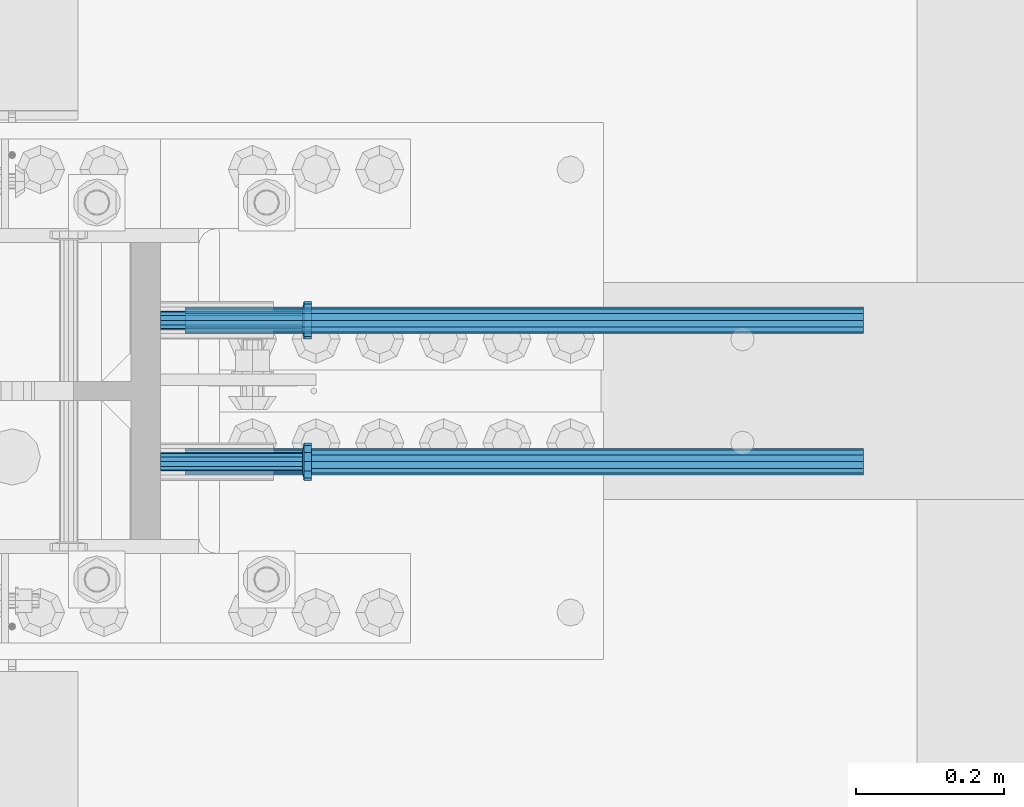
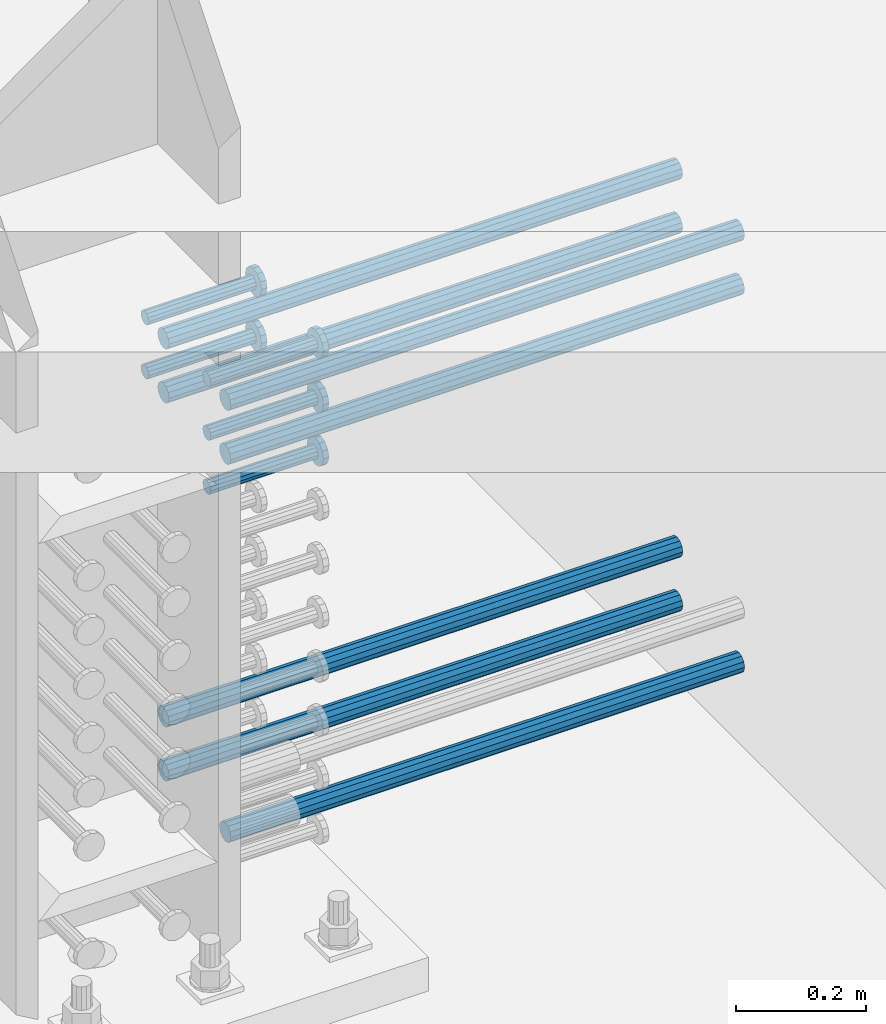
# One storey, part 1195 of 1763: 12 beams, 8 elements without a shape of their own.
"""IFC2X3 building model written with IfcOpenShell, lengths in millimetres."""

from ifc_helpers import new_model, si_unit, frame, origin_with_axes, place, context, subcontext, project, spatial, faceted_brep, material, type_object, element, aggregate, save


model = new_model("IFC2X3")

# Units and contexts
model_context = context("Model", 3, precision=1e-05, world=origin_with_axes())
body_context = subcontext(model_context, "Body", "Model", "MODEL_VIEW")
ifc_project = project(units=[si_unit("LENGTHUNIT", "METRE", prefix="MILLI"), si_unit("AREAUNIT", "SQUARE_METRE"), si_unit("VOLUMEUNIT", "CUBIC_METRE"), si_unit("MASSUNIT", "GRAM", prefix="KILO"), si_unit("TIMEUNIT", "SECOND"), si_unit("PLANEANGLEUNIT", "RADIAN"), si_unit("SOLIDANGLEUNIT", "STERADIAN"), si_unit("THERMODYNAMICTEMPERATUREUNIT", "DEGREE_CELSIUS"), si_unit("LUMINOUSINTENSITYUNIT", "LUMEN")], contexts=[model_context])

# Site, building, storey
site_placement = place(None, origin_with_axes())
site = spatial("IfcSite", under=ifc_project, at=site_placement, CompositionType="ELEMENT")
building_placement = place(site_placement, origin_with_axes())
building = spatial("IfcBuilding", under=site, at=building_placement, Name="Undefined", CompositionType="ELEMENT")
storey_placement = place(building_placement, origin_with_axes())
storey = spatial("IfcBuildingStorey", under=building, at=storey_placement, Name="Undefined", CompositionType="ELEMENT", Elevation=0.0)

# Assembly, beam
assembly_1_placement = place(storey_placement, origin_with_axes())
assembly_1 = element("IfcElementAssembly", 1, at=assembly_1_placement, inside=storey, Name="REBAR", AssemblyPlace="NOTDEFINED", PredefinedType="RIGID_FRAME")
ifc_material_1 = material(Name="STEEL/A706-GR.80")
beam_type_1 = type_object("IfcBeamType", Name="#11 REBAR", PredefinedType="NOTDEFINED")
beam_1_placement = place(assembly_1_placement, frame((-72258.2462049617, 552.449999999157, 4165.60000000003), z_axis=(0.0, 0.0, 1.0), x_axis=(1.0, 0.0, 0.0)))
beam_1 = element("IfcBeam", 2, at=beam_1_placement, type_object=beam_type_1, material=ifc_material_1, Name="REBAR", ObjectType="#11 REBAR", context=body_context, shape_type="Brep", body=[
    faceted_brep([(0.0, -17.9069999999992, 0.0), (0.0, -15.507916905568, -8.95349999999962), (914.400000001086, -15.507916905568, -8.95349999999962), (914.400000001086, -17.9069999999992, 0.0), (0.0, -8.95349999999962, -15.507916905568), (914.400000001086, -8.95349999999962, -15.507916905568), (0.0, 0.0, -17.9070000000002), (914.400000001086, 0.0, -17.9070000000002), (0.0, 8.95349999999962, -15.507916905568), (914.400000001086, 8.95349999999962, -15.507916905568), (0.0, 15.507916905568, -8.95349999999962), (914.400000001086, 15.507916905568, -8.95349999999962), (0.0, 17.9069999999992, 0.0), (914.400000001086, 17.9069999999992, 0.0), (0.0, 15.507916905568, 8.95349999999962), (914.400000001086, 15.507916905568, 8.95349999999962), (0.0, 8.95349999999962, 15.507916905568), (914.400000001086, 8.95349999999962, 15.507916905568), (0.0, 0.0, 17.9070000000002), (914.400000001086, 0.0, 17.9070000000002), (0.0, -8.95349999999962, 15.507916905568), (914.400000001086, -8.95349999999962, 15.507916905568), (0.0, -15.507916905568, 8.95349999999962), (914.400000001086, -15.507916905568, 8.95349999999962)], [[[0, 1, 2, 3]], [[1, 4, 5, 2]], [[4, 6, 7, 5]], [[6, 8, 9, 7]], [[8, 10, 11, 9]], [[10, 12, 13, 11]], [[12, 14, 15, 13]], [[14, 16, 17, 15]], [[16, 18, 19, 17]], [[18, 20, 21, 19]], [[20, 22, 23, 21]], [[22, 0, 3, 23]], [[5, 7, 9, 11, 13, 15, 17, 19, 21, 23, 3, 2]], [[22, 20, 18, 16, 14, 12, 10, 8, 6, 4, 1, 0]]]),
])
aggregate(assembly_1, [beam_1])

assembly_2_placement = place(storey_placement, origin_with_axes())
assembly_2 = element("IfcElementAssembly", 3, at=assembly_2_placement, inside=storey, Name="REBAR", AssemblyPlace="NOTDEFINED", PredefinedType="RIGID_FRAME")
beam_2_placement = place(assembly_2_placement, frame((-72258.2462736235, 361.949999999746, 4064.00000000003), z_axis=(0.0, 0.0, 1.0), x_axis=(1.0, 0.0, 0.0)))
beam_2 = element("IfcBeam", 4, at=beam_2_placement, type_object=beam_type_1, material=ifc_material_1, Name="REBAR", ObjectType="#11 REBAR", context=body_context, shape_type="Brep", body=[
    faceted_brep([(0.0, -17.9069999999992, 0.0), (0.0, -15.507916905568, -8.95349999999962), (914.400000001086, -15.507916905568, -8.95349999999962), (914.400000001086, -17.9069999999992, 0.0), (0.0, -8.95349999999962, -15.507916905568), (914.400000001086, -8.95349999999962, -15.507916905568), (0.0, 0.0, -17.9070000000002), (914.400000001086, 0.0, -17.9070000000002), (0.0, 8.95349999999962, -15.507916905568), (914.400000001086, 8.95349999999962, -15.507916905568), (0.0, 15.507916905568, -8.95349999999962), (914.400000001086, 15.507916905568, -8.95349999999962), (0.0, 17.9069999999992, 0.0), (914.400000001086, 17.9069999999992, 0.0), (0.0, 15.507916905568, 8.95349999999962), (914.400000001086, 15.507916905568, 8.95349999999962), (0.0, 8.95349999999962, 15.507916905568), (914.400000001086, 8.95349999999962, 15.507916905568), (0.0, 0.0, 17.9070000000002), (914.400000001086, 0.0, 17.9070000000002), (0.0, -8.95349999999962, 15.507916905568), (914.400000001086, -8.95349999999962, 15.507916905568), (0.0, -15.507916905568, 8.95349999999962), (914.400000001086, -15.507916905568, 8.95349999999962)], [[[0, 1, 2, 3]], [[1, 4, 5, 2]], [[4, 6, 7, 5]], [[6, 8, 9, 7]], [[8, 10, 11, 9]], [[10, 12, 13, 11]], [[12, 14, 15, 13]], [[14, 16, 17, 15]], [[16, 18, 19, 17]], [[18, 20, 21, 19]], [[20, 22, 23, 21]], [[22, 0, 3, 23]], [[5, 7, 9, 11, 13, 15, 17, 19, 21, 23, 3, 2]], [[22, 20, 18, 16, 14, 12, 10, 8, 6, 4, 1, 0]]]),
])
aggregate(assembly_2, [beam_2])

assembly_3_placement = place(storey_placement, origin_with_axes())
assembly_3 = element("IfcElementAssembly", 5, at=assembly_3_placement, inside=storey, Name="REBAR", AssemblyPlace="NOTDEFINED", PredefinedType="RIGID_FRAME")
beam_3_placement = place(assembly_3_placement, frame((-72258.2462049617, 552.44999999916, 4064.00000000003), z_axis=(0.0, 0.0, 1.0), x_axis=(1.0, 0.0, 0.0)))
beam_3 = element("IfcBeam", 6, at=beam_3_placement, type_object=beam_type_1, material=ifc_material_1, Name="REBAR", ObjectType="#11 REBAR", context=body_context, shape_type="Brep", body=[
    faceted_brep([(0.0, -17.9069999999992, 0.0), (0.0, -15.507916905568, -8.95349999999962), (914.400000001086, -15.507916905568, -8.95349999999962), (914.400000001086, -17.9069999999992, 0.0), (0.0, -8.95349999999962, -15.507916905568), (914.400000001086, -8.95349999999962, -15.507916905568), (0.0, 0.0, -17.9070000000002), (914.400000001086, 0.0, -17.9070000000002), (0.0, 8.95349999999962, -15.507916905568), (914.400000001086, 8.95349999999962, -15.507916905568), (0.0, 15.507916905568, -8.95349999999962), (914.400000001086, 15.507916905568, -8.95349999999962), (0.0, 17.9069999999992, 0.0), (914.400000001086, 17.9069999999992, 0.0), (0.0, 15.507916905568, 8.95349999999962), (914.400000001086, 15.507916905568, 8.95349999999962), (0.0, 8.95349999999962, 15.507916905568), (914.400000001086, 8.95349999999962, 15.507916905568), (0.0, 0.0, 17.9070000000002), (914.400000001086, 0.0, 17.9070000000002), (0.0, -8.95349999999962, 15.507916905568), (914.400000001086, -8.95349999999962, 15.507916905568), (0.0, -15.507916905568, 8.95349999999962), (914.400000001086, -15.507916905568, 8.95349999999962)], [[[0, 1, 2, 3]], [[1, 4, 5, 2]], [[4, 6, 7, 5]], [[6, 8, 9, 7]], [[8, 10, 11, 9]], [[10, 12, 13, 11]], [[12, 14, 15, 13]], [[14, 16, 17, 15]], [[16, 18, 19, 17]], [[18, 20, 21, 19]], [[20, 22, 23, 21]], [[22, 0, 3, 23]], [[5, 7, 9, 11, 13, 15, 17, 19, 21, 23, 3, 2]], [[22, 20, 18, 16, 14, 12, 10, 8, 6, 4, 1, 0]]]),
])
aggregate(assembly_3, [beam_3])

assembly_4_placement = place(storey_placement, origin_with_axes())
assembly_4 = element("IfcElementAssembly", 7, at=assembly_4_placement, inside=storey, Name="REBAR", AssemblyPlace="NOTDEFINED", PredefinedType="RIGID_FRAME")
beam_4_placement = place(assembly_4_placement, frame((-72258.246342359, 361.949999999741, 4876.80000000009), z_axis=(0.0, 0.0, 1.0), x_axis=(1.0, 0.0, 0.0)))
beam_4 = element("IfcBeam", 8, at=beam_4_placement, type_object=beam_type_1, material=ifc_material_1, Name="REBAR", ObjectType="#11 REBAR", context=body_context, shape_type="Brep", body=[
    faceted_brep([(0.0, -17.9069999999992, 0.0), (0.0, -15.507916905568, -8.95349999999962), (914.400000001086, -15.507916905568, -8.95349999999962), (914.400000001086, -17.9069999999992, 0.0), (0.0, -8.95349999999962, -15.507916905568), (914.400000001086, -8.95349999999962, -15.507916905568), (0.0, 0.0, -17.9070000000002), (914.400000001086, 0.0, -17.9070000000002), (0.0, 8.95349999999962, -15.507916905568), (914.400000001086, 8.95349999999962, -15.507916905568), (0.0, 15.507916905568, -8.95349999999962), (914.400000001086, 15.507916905568, -8.95349999999962), (0.0, 17.9069999999992, 0.0), (914.400000001086, 17.9069999999992, 0.0), (0.0, 15.507916905568, 8.95349999999962), (914.400000001086, 15.507916905568, 8.95349999999962), (0.0, 8.95349999999962, 15.507916905568), (914.400000001086, 8.95349999999962, 15.507916905568), (0.0, 0.0, 17.9070000000002), (914.400000001086, 0.0, 17.9070000000002), (0.0, -8.95349999999962, 15.507916905568), (914.400000001086, -8.95349999999962, 15.507916905568), (0.0, -15.507916905568, 8.95349999999962), (914.400000001086, -15.507916905568, 8.95349999999962)], [[[0, 1, 2, 3]], [[1, 4, 5, 2]], [[4, 6, 7, 5]], [[6, 8, 9, 7]], [[8, 10, 11, 9]], [[10, 12, 13, 11]], [[12, 14, 15, 13]], [[14, 16, 17, 15]], [[16, 18, 19, 17]], [[18, 20, 21, 19]], [[20, 22, 23, 21]], [[22, 0, 3, 23]], [[5, 7, 9, 11, 13, 15, 17, 19, 21, 23, 3, 2]], [[22, 20, 18, 16, 14, 12, 10, 8, 6, 4, 1, 0]]]),
])
aggregate(assembly_4, [beam_4])

assembly_5_placement = place(storey_placement, origin_with_axes())
assembly_5 = element("IfcElementAssembly", 9, at=assembly_5_placement, inside=storey, Name="REBAR", AssemblyPlace="NOTDEFINED", PredefinedType="RIGID_FRAME")
beam_5_placement = place(assembly_5_placement, frame((-72258.2462736978, 552.449999999155, 4876.80000000009), z_axis=(0.0, 0.0, 1.0), x_axis=(1.0, 0.0, 0.0)))
beam_5 = element("IfcBeam", 10, at=beam_5_placement, type_object=beam_type_1, material=ifc_material_1, Name="REBAR", ObjectType="#11 REBAR", context=body_context, shape_type="Brep", body=[
    faceted_brep([(0.0, -17.9069999999992, 0.0), (0.0, -15.507916905568, -8.95349999999962), (914.400000001086, -15.507916905568, -8.95349999999962), (914.400000001086, -17.9069999999992, 0.0), (0.0, -8.95349999999962, -15.507916905568), (914.400000001086, -8.95349999999962, -15.507916905568), (0.0, 0.0, -17.9070000000002), (914.400000001086, 0.0, -17.9070000000002), (0.0, 8.95349999999962, -15.507916905568), (914.400000001086, 8.95349999999962, -15.507916905568), (0.0, 15.507916905568, -8.95349999999962), (914.400000001086, 15.507916905568, -8.95349999999962), (0.0, 17.9069999999992, 0.0), (914.400000001086, 17.9069999999992, 0.0), (0.0, 15.507916905568, 8.95349999999962), (914.400000001086, 15.507916905568, 8.95349999999962), (0.0, 8.95349999999962, 15.507916905568), (914.400000001086, 8.95349999999962, 15.507916905568), (0.0, 0.0, 17.9070000000002), (914.400000001086, 0.0, 17.9070000000002), (0.0, -8.95349999999962, 15.507916905568), (914.400000001086, -8.95349999999962, 15.507916905568), (0.0, -15.507916905568, 8.95349999999962), (914.400000001086, -15.507916905568, 8.95349999999962)], [[[0, 1, 2, 3]], [[1, 4, 5, 2]], [[4, 6, 7, 5]], [[6, 8, 9, 7]], [[8, 10, 11, 9]], [[10, 12, 13, 11]], [[12, 14, 15, 13]], [[14, 16, 17, 15]], [[16, 18, 19, 17]], [[18, 20, 21, 19]], [[20, 22, 23, 21]], [[22, 0, 3, 23]], [[5, 7, 9, 11, 13, 15, 17, 19, 21, 23, 3, 2]], [[22, 20, 18, 16, 14, 12, 10, 8, 6, 4, 1, 0]]]),
])
aggregate(assembly_5, [beam_5])

assembly_6_placement = place(storey_placement, origin_with_axes())
assembly_6 = element("IfcElementAssembly", 11, at=assembly_6_placement, inside=storey, Name="REBAR", AssemblyPlace="NOTDEFINED", PredefinedType="RIGID_FRAME")
beam_6_placement = place(assembly_6_placement, frame((-72258.246342359, 361.949999999744, 4775.20000000009), z_axis=(0.0, 0.0, 1.0), x_axis=(1.0, 0.0, 0.0)))
beam_6 = element("IfcBeam", 12, at=beam_6_placement, type_object=beam_type_1, material=ifc_material_1, Name="REBAR", ObjectType="#11 REBAR", context=body_context, shape_type="Brep", body=[
    faceted_brep([(0.0, -17.9069999999992, 0.0), (0.0, -15.507916905568, -8.95349999999962), (914.400000001086, -15.507916905568, -8.95349999999962), (914.400000001086, -17.9069999999992, 0.0), (0.0, -8.95349999999962, -15.507916905568), (914.400000001086, -8.95349999999962, -15.507916905568), (0.0, 0.0, -17.9070000000002), (914.400000001086, 0.0, -17.9070000000002), (0.0, 8.95349999999962, -15.507916905568), (914.400000001086, 8.95349999999962, -15.507916905568), (0.0, 15.507916905568, -8.95349999999962), (914.400000001086, 15.507916905568, -8.95349999999962), (0.0, 17.9069999999992, 0.0), (914.400000001086, 17.9069999999992, 0.0), (0.0, 15.507916905568, 8.95349999999962), (914.400000001086, 15.507916905568, 8.95349999999962), (0.0, 8.95349999999962, 15.507916905568), (914.400000001086, 8.95349999999962, 15.507916905568), (0.0, 0.0, 17.9070000000002), (914.400000001086, 0.0, 17.9070000000002), (0.0, -8.95349999999962, 15.507916905568), (914.400000001086, -8.95349999999962, 15.507916905568), (0.0, -15.507916905568, 8.95349999999962), (914.400000001086, -15.507916905568, 8.95349999999962)], [[[0, 1, 2, 3]], [[1, 4, 5, 2]], [[4, 6, 7, 5]], [[6, 8, 9, 7]], [[8, 10, 11, 9]], [[10, 12, 13, 11]], [[12, 14, 15, 13]], [[14, 16, 17, 15]], [[16, 18, 19, 17]], [[18, 20, 21, 19]], [[20, 22, 23, 21]], [[22, 0, 3, 23]], [[5, 7, 9, 11, 13, 15, 17, 19, 21, 23, 3, 2]], [[22, 20, 18, 16, 14, 12, 10, 8, 6, 4, 1, 0]]]),
])
aggregate(assembly_6, [beam_6])

assembly_7_placement = place(storey_placement, origin_with_axes())
assembly_7 = element("IfcElementAssembly", 13, at=assembly_7_placement, inside=storey, Name="REBAR", AssemblyPlace="NOTDEFINED", PredefinedType="RIGID_FRAME")
beam_7_placement = place(assembly_7_placement, frame((-72258.2462736978, 552.449999999159, 4775.20000000009), z_axis=(0.0, 0.0, 1.0), x_axis=(1.0, 0.0, 0.0)))
beam_7 = element("IfcBeam", 14, at=beam_7_placement, type_object=beam_type_1, material=ifc_material_1, Name="REBAR", ObjectType="#11 REBAR", context=body_context, shape_type="Brep", body=[
    faceted_brep([(0.0, -17.9069999999992, 0.0), (0.0, -15.507916905568, -8.95349999999962), (914.400000001086, -15.507916905568, -8.95349999999962), (914.400000001086, -17.9069999999992, 0.0), (0.0, -8.95349999999962, -15.507916905568), (914.400000001086, -8.95349999999962, -15.507916905568), (0.0, 0.0, -17.9070000000002), (914.400000001086, 0.0, -17.9070000000002), (0.0, 8.95349999999962, -15.507916905568), (914.400000001086, 8.95349999999962, -15.507916905568), (0.0, 15.507916905568, -8.95349999999962), (914.400000001086, 15.507916905568, -8.95349999999962), (0.0, 17.9069999999992, 0.0), (914.400000001086, 17.9069999999992, 0.0), (0.0, 15.507916905568, 8.95349999999962), (914.400000001086, 15.507916905568, 8.95349999999962), (0.0, 8.95349999999962, 15.507916905568), (914.400000001086, 8.95349999999962, 15.507916905568), (0.0, 0.0, 17.9070000000002), (914.400000001086, 0.0, 17.9070000000002), (0.0, -8.95349999999962, 15.507916905568), (914.400000001086, -8.95349999999962, 15.507916905568), (0.0, -15.507916905568, 8.95349999999962), (914.400000001086, -15.507916905568, 8.95349999999962)], [[[0, 1, 2, 3]], [[1, 4, 5, 2]], [[4, 6, 7, 5]], [[6, 8, 9, 7]], [[8, 10, 11, 9]], [[10, 12, 13, 11]], [[12, 14, 15, 13]], [[14, 16, 17, 15]], [[16, 18, 19, 17]], [[18, 20, 21, 19]], [[20, 22, 23, 21]], [[22, 0, 3, 23]], [[5, 7, 9, 11, 13, 15, 17, 19, 21, 23, 3, 2]], [[22, 20, 18, 16, 14, 12, 10, 8, 6, 4, 1, 0]]]),
])
aggregate(assembly_7, [beam_7])

# Assembly, beams
assembly_8_placement = place(storey_placement, origin_with_axes())
assembly_8 = element("IfcElementAssembly", 15, at=assembly_8_placement, inside=storey, Name="COLUMN", AssemblyPlace="NOTDEFINED", PredefinedType="RIGID_FRAME")
ifc_material_2 = material(Name="STEEL/A108")
beam_type_2 = type_object("IfcBeamType", PredefinedType="NOTDEFINED")
beam_8_placement = place(assembly_8_placement, frame((-72291.0121160557, 361.950000001446, 4927.60000000008), z_axis=(0.0, 1.0, 0.0), x_axis=(1.0, 0.0, 0.0)))
beam_8 = element("IfcBeam", 16, at=beam_8_placement, type_object=beam_type_2, material=ifc_material_2, Name="HEADED STUD ANCHOR", context=body_context, shape_type="Brep", body=[
    faceted_brep([(0.0, -12.6999999999971, -1.81898940354586e-12), (3.63797880709171e-12, -11.0, -6.34999990463257), (191.00799999576, -11.0, -6.34999990454889), (191.007999995752, -12.6999998092651, 8.36735125631094e-11), (7.27595761418343e-12, -6.34999990463257, -11.0), (191.00799999576, -6.34999990463257, -10.9999999999163), (3.63797880709171e-12, 0.0, -12.6999998092651), (191.00799999576, 0.0, -12.6999998091815), (7.27595761418343e-12, 6.34999990463257, -11.0), (191.00799999576, 6.34999990463257, -10.9999999999163), (3.63797880709171e-12, 11.0, -6.34999990463257), (191.00799999576, 11.0, -6.34999990454889), (0.0, 12.6999999999971, -1.81898940354586e-12), (191.007999995752, 12.6999998092651, 8.36735125631094e-11), (0.0, 11.0, 6.34999990463257), (191.007999995752, 11.0, 6.34999990471624), (-3.63797880709171e-12, 6.34999990463257, 11.0), (191.007999995749, 6.34999990463257, 11.0000000000837), (-3.63797880709171e-12, 0.0, 12.6999998092651), (191.007999995749, 0.0, 12.6999998093488), (-3.63797880709171e-12, -6.34999990463257, 11.0), (191.007999995749, -6.34999990463257, 11.0000000000837), (0.0, -11.0, 6.34999990463257), (191.007999995752, -11.0, 6.34999990471624), (193.039999995715, -22.0, -12.6999998091796), (193.039999995708, -25.3999996185303, 8.54925019666553e-11), (193.039999995719, -12.6999998092651, -21.9999999999145), (193.039999995719, 0.0, -25.3999996184448), (193.039999995719, 12.6999998092651, -21.9999999999145), (193.039999995715, 22.0, -12.6999998091796), (193.039999995708, 25.3999996185303, 8.54925019666553e-11), (193.039999995704, 22.0, 12.6999998093506), (193.039999995701, 12.6999998092651, 22.0000000000855), (193.039999995697, 0.0, 25.3999996186158), (193.039999995701, -12.6999998092651, 22.0000000000855), (193.039999995704, -22.0, 12.6999998093506), (203.199999995486, -22.0, -12.6999998091742), (203.199999995482, -25.3999996185303, 9.09494701772928e-11), (203.199999995493, -12.6999998092651, -21.9999999999091), (203.199999995493, 0.0, -25.3999996184393), (203.199999995493, 12.6999998092651, -21.9999999999091), (203.199999995486, 22.0, -12.6999998091742), (203.199999995482, 25.3999996185303, 9.09494701772928e-11), (203.199999995479, 22.0, 12.6999998093561), (203.199999995475, 12.6999998092651, 22.0000000000909), (203.199999995471, 0.0, 25.3999996186212), (203.199999995475, -12.6999998092651, 22.0000000000909), (203.199999995479, -22.0, 12.6999998093561)], [[[0, 1, 2, 3]], [[1, 4, 5, 2]], [[4, 6, 7, 5]], [[6, 8, 9, 7]], [[8, 10, 11, 9]], [[10, 12, 13, 11]], [[12, 14, 15, 13]], [[14, 16, 17, 15]], [[16, 18, 19, 17]], [[18, 20, 21, 19]], [[20, 22, 23, 21]], [[22, 0, 3, 23]], [[22, 20, 18, 16, 14, 12, 10, 8, 6, 4, 1, 0]], [[3, 2, 24, 25]], [[2, 5, 26, 24]], [[5, 7, 27, 26]], [[7, 9, 28, 27]], [[9, 11, 29, 28]], [[11, 13, 30, 29]], [[13, 15, 31, 30]], [[15, 17, 32, 31]], [[17, 19, 33, 32]], [[19, 21, 34, 33]], [[21, 23, 35, 34]], [[23, 3, 25, 35]], [[25, 24, 36, 37]], [[24, 26, 38, 36]], [[26, 27, 39, 38]], [[27, 28, 40, 39]], [[28, 29, 41, 40]], [[29, 30, 42, 41]], [[30, 31, 43, 42]], [[31, 32, 44, 43]], [[32, 33, 45, 44]], [[33, 34, 46, 45]], [[34, 35, 47, 46]], [[35, 25, 37, 47]], [[38, 39, 40, 41, 42, 43, 44, 45, 46, 47, 37, 36]]]),
])
beam_9_placement = place(assembly_8_placement, frame((-72291.0120473952, 552.450000000834, 4927.60000000008), z_axis=(0.0, 1.0, 0.0), x_axis=(1.0, 0.0, 0.0)))
beam_9 = element("IfcBeam", 17, at=beam_9_placement, type_object=beam_type_2, material=ifc_material_2, Name="HEADED STUD ANCHOR", context=body_context, shape_type="Brep", body=[
    faceted_brep([(0.0, -12.6999999999971, -1.81898940354586e-12), (3.63797880709171e-12, -11.0, -6.34999990463257), (191.00799999576, -11.0, -6.34999990454889), (191.007999995752, -12.6999998092651, 8.36735125631094e-11), (7.27595761418343e-12, -6.34999990463257, -11.0), (191.00799999576, -6.34999990463257, -10.9999999999163), (3.63797880709171e-12, 0.0, -12.6999998092651), (191.00799999576, 0.0, -12.6999998091815), (7.27595761418343e-12, 6.34999990463257, -11.0), (191.00799999576, 6.34999990463257, -10.9999999999163), (3.63797880709171e-12, 11.0, -6.34999990463257), (191.00799999576, 11.0, -6.34999990454889), (0.0, 12.6999999999971, -1.81898940354586e-12), (191.007999995752, 12.6999998092651, 8.36735125631094e-11), (0.0, 11.0, 6.34999990463257), (191.007999995752, 11.0, 6.34999990471624), (-3.63797880709171e-12, 6.34999990463257, 11.0), (191.007999995749, 6.34999990463257, 11.0000000000837), (-3.63797880709171e-12, 0.0, 12.6999998092651), (191.007999995749, 0.0, 12.6999998093488), (-3.63797880709171e-12, -6.34999990463257, 11.0), (191.007999995749, -6.34999990463257, 11.0000000000837), (0.0, -11.0, 6.34999990463257), (191.007999995752, -11.0, 6.34999990471624), (193.039999995715, -22.0, -12.6999998091796), (193.039999995708, -25.3999996185303, 8.54925019666553e-11), (193.039999995719, -12.6999998092651, -21.9999999999145), (193.039999995719, 0.0, -25.3999996184448), (193.039999995719, 12.6999998092651, -21.9999999999145), (193.039999995715, 22.0, -12.6999998091796), (193.039999995708, 25.3999996185303, 8.54925019666553e-11), (193.039999995704, 22.0, 12.6999998093506), (193.039999995701, 12.6999998092651, 22.0000000000855), (193.039999995697, 0.0, 25.3999996186158), (193.039999995701, -12.6999998092651, 22.0000000000855), (193.039999995704, -22.0, 12.6999998093506), (203.199999995486, -22.0, -12.6999998091742), (203.199999995482, -25.3999996185303, 9.09494701772928e-11), (203.199999995493, -12.6999998092651, -21.9999999999091), (203.199999995493, 0.0, -25.3999996184393), (203.199999995493, 12.6999998092651, -21.9999999999091), (203.199999995486, 22.0, -12.6999998091742), (203.199999995482, 25.3999996185303, 9.09494701772928e-11), (203.199999995479, 22.0, 12.6999998093561), (203.199999995475, 12.6999998092651, 22.0000000000909), (203.199999995471, 0.0, 25.3999996186212), (203.199999995475, -12.6999998092651, 22.0000000000909), (203.199999995479, -22.0, 12.6999998093561)], [[[0, 1, 2, 3]], [[1, 4, 5, 2]], [[4, 6, 7, 5]], [[6, 8, 9, 7]], [[8, 10, 11, 9]], [[10, 12, 13, 11]], [[12, 14, 15, 13]], [[14, 16, 17, 15]], [[16, 18, 19, 17]], [[18, 20, 21, 19]], [[20, 22, 23, 21]], [[22, 0, 3, 23]], [[22, 20, 18, 16, 14, 12, 10, 8, 6, 4, 1, 0]], [[3, 2, 24, 25]], [[2, 5, 26, 24]], [[5, 7, 27, 26]], [[7, 9, 28, 27]], [[9, 11, 29, 28]], [[11, 13, 30, 29]], [[13, 15, 31, 30]], [[15, 17, 32, 31]], [[17, 19, 33, 32]], [[19, 21, 34, 33]], [[21, 23, 35, 34]], [[23, 3, 25, 35]], [[25, 24, 36, 37]], [[24, 26, 38, 36]], [[26, 27, 39, 38]], [[27, 28, 40, 39]], [[28, 29, 41, 40]], [[29, 30, 42, 41]], [[30, 31, 43, 42]], [[31, 32, 44, 43]], [[32, 33, 45, 44]], [[33, 34, 46, 45]], [[34, 35, 47, 46]], [[35, 25, 37, 47]], [[38, 39, 40, 41, 42, 43, 44, 45, 46, 47, 37, 36]]]),
])
beam_10_placement = place(assembly_8_placement, frame((-72291.0120473202, 361.950000001446, 4826.00000000007), z_axis=(0.0, 1.0, 0.0), x_axis=(1.0, 0.0, 0.0)))
beam_10 = element("IfcBeam", 18, at=beam_10_placement, type_object=beam_type_2, material=ifc_material_2, Name="HEADED STUD ANCHOR", context=body_context, shape_type="Brep", body=[
    faceted_brep([(0.0, -12.6999999999971, -1.81898940354586e-12), (3.63797880709171e-12, -11.0, -6.34999990463257), (191.00799999576, -11.0, -6.34999990454889), (191.007999995752, -12.6999998092651, 8.36735125631094e-11), (7.27595761418343e-12, -6.34999990463257, -11.0), (191.00799999576, -6.34999990463257, -10.9999999999163), (3.63797880709171e-12, 0.0, -12.6999998092651), (191.00799999576, 0.0, -12.6999998091815), (7.27595761418343e-12, 6.34999990463257, -11.0), (191.00799999576, 6.34999990463257, -10.9999999999163), (3.63797880709171e-12, 11.0, -6.34999990463257), (191.00799999576, 11.0, -6.34999990454889), (0.0, 12.6999999999971, -1.81898940354586e-12), (191.007999995752, 12.6999998092651, 8.36735125631094e-11), (0.0, 11.0, 6.34999990463257), (191.007999995752, 11.0, 6.34999990471624), (-3.63797880709171e-12, 6.34999990463257, 11.0), (191.007999995749, 6.34999990463257, 11.0000000000837), (-3.63797880709171e-12, 0.0, 12.6999998092651), (191.007999995749, 0.0, 12.6999998093488), (-3.63797880709171e-12, -6.34999990463257, 11.0), (191.007999995749, -6.34999990463257, 11.0000000000837), (0.0, -11.0, 6.34999990463257), (191.007999995752, -11.0, 6.34999990471624), (193.039999995715, -22.0, -12.6999998091796), (193.039999995708, -25.3999996185303, 8.54925019666553e-11), (193.039999995719, -12.6999998092651, -21.9999999999145), (193.039999995719, 0.0, -25.3999996184448), (193.039999995719, 12.6999998092651, -21.9999999999145), (193.039999995715, 22.0, -12.6999998091796), (193.039999995708, 25.3999996185303, 8.54925019666553e-11), (193.039999995704, 22.0, 12.6999998093506), (193.039999995701, 12.6999998092651, 22.0000000000855), (193.039999995697, 0.0, 25.3999996186158), (193.039999995701, -12.6999998092651, 22.0000000000855), (193.039999995704, -22.0, 12.6999998093506), (203.199999995486, -22.0, -12.6999998091742), (203.199999995482, -25.3999996185303, 9.09494701772928e-11), (203.199999995493, -12.6999998092651, -21.9999999999091), (203.199999995493, 0.0, -25.3999996184393), (203.199999995493, 12.6999998092651, -21.9999999999091), (203.199999995486, 22.0, -12.6999998091742), (203.199999995482, 25.3999996185303, 9.09494701772928e-11), (203.199999995479, 22.0, 12.6999998093561), (203.199999995475, 12.6999998092651, 22.0000000000909), (203.199999995471, 0.0, 25.3999996186212), (203.199999995475, -12.6999998092651, 22.0000000000909), (203.199999995479, -22.0, 12.6999998093561)], [[[0, 1, 2, 3]], [[1, 4, 5, 2]], [[4, 6, 7, 5]], [[6, 8, 9, 7]], [[8, 10, 11, 9]], [[10, 12, 13, 11]], [[12, 14, 15, 13]], [[14, 16, 17, 15]], [[16, 18, 19, 17]], [[18, 20, 21, 19]], [[20, 22, 23, 21]], [[22, 0, 3, 23]], [[22, 20, 18, 16, 14, 12, 10, 8, 6, 4, 1, 0]], [[3, 2, 24, 25]], [[2, 5, 26, 24]], [[5, 7, 27, 26]], [[7, 9, 28, 27]], [[9, 11, 29, 28]], [[11, 13, 30, 29]], [[13, 15, 31, 30]], [[15, 17, 32, 31]], [[17, 19, 33, 32]], [[19, 21, 34, 33]], [[21, 23, 35, 34]], [[23, 3, 25, 35]], [[25, 24, 36, 37]], [[24, 26, 38, 36]], [[26, 27, 39, 38]], [[27, 28, 40, 39]], [[28, 29, 41, 40]], [[29, 30, 42, 41]], [[30, 31, 43, 42]], [[31, 32, 44, 43]], [[32, 33, 45, 44]], [[33, 34, 46, 45]], [[34, 35, 47, 46]], [[35, 25, 37, 47]], [[38, 39, 40, 41, 42, 43, 44, 45, 46, 47, 37, 36]]]),
])
beam_11_placement = place(assembly_8_placement, frame((-72291.0119786597, 552.450000000834, 4826.00000000007), z_axis=(0.0, 1.0, 0.0), x_axis=(1.0, 0.0, 0.0)))
beam_11 = element("IfcBeam", 19, at=beam_11_placement, type_object=beam_type_2, material=ifc_material_2, Name="HEADED STUD ANCHOR", context=body_context, shape_type="Brep", body=[
    faceted_brep([(0.0, -12.6999999999971, -1.81898940354586e-12), (3.63797880709171e-12, -11.0, -6.34999990463257), (191.00799999576, -11.0, -6.34999990454889), (191.007999995752, -12.6999998092651, 8.36735125631094e-11), (7.27595761418343e-12, -6.34999990463257, -11.0), (191.00799999576, -6.34999990463257, -10.9999999999163), (3.63797880709171e-12, 0.0, -12.6999998092651), (191.00799999576, 0.0, -12.6999998091815), (7.27595761418343e-12, 6.34999990463257, -11.0), (191.00799999576, 6.34999990463257, -10.9999999999163), (3.63797880709171e-12, 11.0, -6.34999990463257), (191.00799999576, 11.0, -6.34999990454889), (0.0, 12.6999999999971, -1.81898940354586e-12), (191.007999995752, 12.6999998092651, 8.36735125631094e-11), (0.0, 11.0, 6.34999990463257), (191.007999995752, 11.0, 6.34999990471624), (-3.63797880709171e-12, 6.34999990463257, 11.0), (191.007999995749, 6.34999990463257, 11.0000000000837), (-3.63797880709171e-12, 0.0, 12.6999998092651), (191.007999995749, 0.0, 12.6999998093488), (-3.63797880709171e-12, -6.34999990463257, 11.0), (191.007999995749, -6.34999990463257, 11.0000000000837), (0.0, -11.0, 6.34999990463257), (191.007999995752, -11.0, 6.34999990471624), (193.039999995715, -22.0, -12.6999998091796), (193.039999995708, -25.3999996185303, 8.54925019666553e-11), (193.039999995719, -12.6999998092651, -21.9999999999145), (193.039999995719, 0.0, -25.3999996184448), (193.039999995719, 12.6999998092651, -21.9999999999145), (193.039999995715, 22.0, -12.6999998091796), (193.039999995708, 25.3999996185303, 8.54925019666553e-11), (193.039999995704, 22.0, 12.6999998093506), (193.039999995701, 12.6999998092651, 22.0000000000855), (193.039999995697, 0.0, 25.3999996186158), (193.039999995701, -12.6999998092651, 22.0000000000855), (193.039999995704, -22.0, 12.6999998093506), (203.199999995486, -22.0, -12.6999998091742), (203.199999995482, -25.3999996185303, 9.09494701772928e-11), (203.199999995493, -12.6999998092651, -21.9999999999091), (203.199999995493, 0.0, -25.3999996184393), (203.199999995493, 12.6999998092651, -21.9999999999091), (203.199999995486, 22.0, -12.6999998091742), (203.199999995482, 25.3999996185303, 9.09494701772928e-11), (203.199999995479, 22.0, 12.6999998093561), (203.199999995475, 12.6999998092651, 22.0000000000909), (203.199999995471, 0.0, 25.3999996186212), (203.199999995475, -12.6999998092651, 22.0000000000909), (203.199999995479, -22.0, 12.6999998093561)], [[[0, 1, 2, 3]], [[1, 4, 5, 2]], [[4, 6, 7, 5]], [[6, 8, 9, 7]], [[8, 10, 11, 9]], [[10, 12, 13, 11]], [[12, 14, 15, 13]], [[14, 16, 17, 15]], [[16, 18, 19, 17]], [[18, 20, 21, 19]], [[20, 22, 23, 21]], [[22, 0, 3, 23]], [[22, 20, 18, 16, 14, 12, 10, 8, 6, 4, 1, 0]], [[3, 2, 24, 25]], [[2, 5, 26, 24]], [[5, 7, 27, 26]], [[7, 9, 28, 27]], [[9, 11, 29, 28]], [[11, 13, 30, 29]], [[13, 15, 31, 30]], [[15, 17, 32, 31]], [[17, 19, 33, 32]], [[19, 21, 34, 33]], [[21, 23, 35, 34]], [[23, 3, 25, 35]], [[25, 24, 36, 37]], [[24, 26, 38, 36]], [[26, 27, 39, 38]], [[27, 28, 40, 39]], [[28, 29, 41, 40]], [[29, 30, 42, 41]], [[30, 31, 43, 42]], [[31, 32, 44, 43]], [[32, 33, 45, 44]], [[33, 34, 46, 45]], [[34, 35, 47, 46]], [[35, 25, 37, 47]], [[38, 39, 40, 41, 42, 43, 44, 45, 46, 47, 37, 36]]]),
])
beam_12_placement = place(assembly_8_placement, frame((-72291.0120473202, 361.950000001446, 4724.40000000007), z_axis=(0.0, 1.0, 0.0), x_axis=(1.0, 0.0, 0.0)))
beam_12 = element("IfcBeam", 20, at=beam_12_placement, type_object=beam_type_2, material=ifc_material_2, Name="HEADED STUD ANCHOR", context=body_context, shape_type="Brep", body=[
    faceted_brep([(0.0, -12.6999999999971, -1.81898940354586e-12), (3.63797880709171e-12, -11.0, -6.34999990463257), (191.00799999576, -11.0, -6.34999990454889), (191.007999995752, -12.6999998092651, 8.36735125631094e-11), (7.27595761418343e-12, -6.34999990463257, -11.0), (191.00799999576, -6.34999990463257, -10.9999999999163), (3.63797880709171e-12, 0.0, -12.6999998092651), (191.00799999576, 0.0, -12.6999998091815), (7.27595761418343e-12, 6.34999990463257, -11.0), (191.00799999576, 6.34999990463257, -10.9999999999163), (3.63797880709171e-12, 11.0, -6.34999990463257), (191.00799999576, 11.0, -6.34999990454889), (0.0, 12.6999999999971, -1.81898940354586e-12), (191.007999995752, 12.6999998092651, 8.36735125631094e-11), (0.0, 11.0, 6.34999990463257), (191.007999995752, 11.0, 6.34999990471624), (-3.63797880709171e-12, 6.34999990463257, 11.0), (191.007999995749, 6.34999990463257, 11.0000000000837), (-3.63797880709171e-12, 0.0, 12.6999998092651), (191.007999995749, 0.0, 12.6999998093488), (-3.63797880709171e-12, -6.34999990463257, 11.0), (191.007999995749, -6.34999990463257, 11.0000000000837), (0.0, -11.0, 6.34999990463257), (191.007999995752, -11.0, 6.34999990471624), (193.039999995715, -22.0, -12.6999998091796), (193.039999995708, -25.3999996185303, 8.54925019666553e-11), (193.039999995719, -12.6999998092651, -21.9999999999145), (193.039999995719, 0.0, -25.3999996184448), (193.039999995719, 12.6999998092651, -21.9999999999145), (193.039999995715, 22.0, -12.6999998091796), (193.039999995708, 25.3999996185303, 8.54925019666553e-11), (193.039999995704, 22.0, 12.6999998093506), (193.039999995701, 12.6999998092651, 22.0000000000855), (193.039999995697, 0.0, 25.3999996186158), (193.039999995701, -12.6999998092651, 22.0000000000855), (193.039999995704, -22.0, 12.6999998093506), (203.199999995486, -22.0, -12.6999998091742), (203.199999995482, -25.3999996185303, 9.09494701772928e-11), (203.199999995493, -12.6999998092651, -21.9999999999091), (203.199999995493, 0.0, -25.3999996184393), (203.199999995493, 12.6999998092651, -21.9999999999091), (203.199999995486, 22.0, -12.6999998091742), (203.199999995482, 25.3999996185303, 9.09494701772928e-11), (203.199999995479, 22.0, 12.6999998093561), (203.199999995475, 12.6999998092651, 22.0000000000909), (203.199999995471, 0.0, 25.3999996186212), (203.199999995475, -12.6999998092651, 22.0000000000909), (203.199999995479, -22.0, 12.6999998093561)], [[[0, 1, 2, 3]], [[1, 4, 5, 2]], [[4, 6, 7, 5]], [[6, 8, 9, 7]], [[8, 10, 11, 9]], [[10, 12, 13, 11]], [[12, 14, 15, 13]], [[14, 16, 17, 15]], [[16, 18, 19, 17]], [[18, 20, 21, 19]], [[20, 22, 23, 21]], [[22, 0, 3, 23]], [[22, 20, 18, 16, 14, 12, 10, 8, 6, 4, 1, 0]], [[3, 2, 24, 25]], [[2, 5, 26, 24]], [[5, 7, 27, 26]], [[7, 9, 28, 27]], [[9, 11, 29, 28]], [[11, 13, 30, 29]], [[13, 15, 31, 30]], [[15, 17, 32, 31]], [[17, 19, 33, 32]], [[19, 21, 34, 33]], [[21, 23, 35, 34]], [[23, 3, 25, 35]], [[25, 24, 36, 37]], [[24, 26, 38, 36]], [[26, 27, 39, 38]], [[27, 28, 40, 39]], [[28, 29, 41, 40]], [[29, 30, 42, 41]], [[30, 31, 43, 42]], [[31, 32, 44, 43]], [[32, 33, 45, 44]], [[33, 34, 46, 45]], [[34, 35, 47, 46]], [[35, 25, 37, 47]], [[38, 39, 40, 41, 42, 43, 44, 45, 46, 47, 37, 36]]]),
])
aggregate(assembly_8, [beam_8, beam_9, beam_10, beam_11, beam_12])

save(model, "model.ifc")
